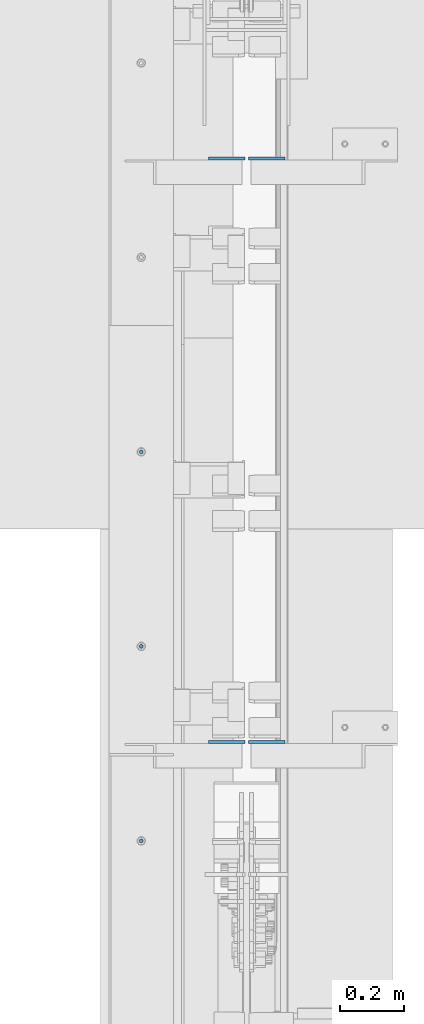
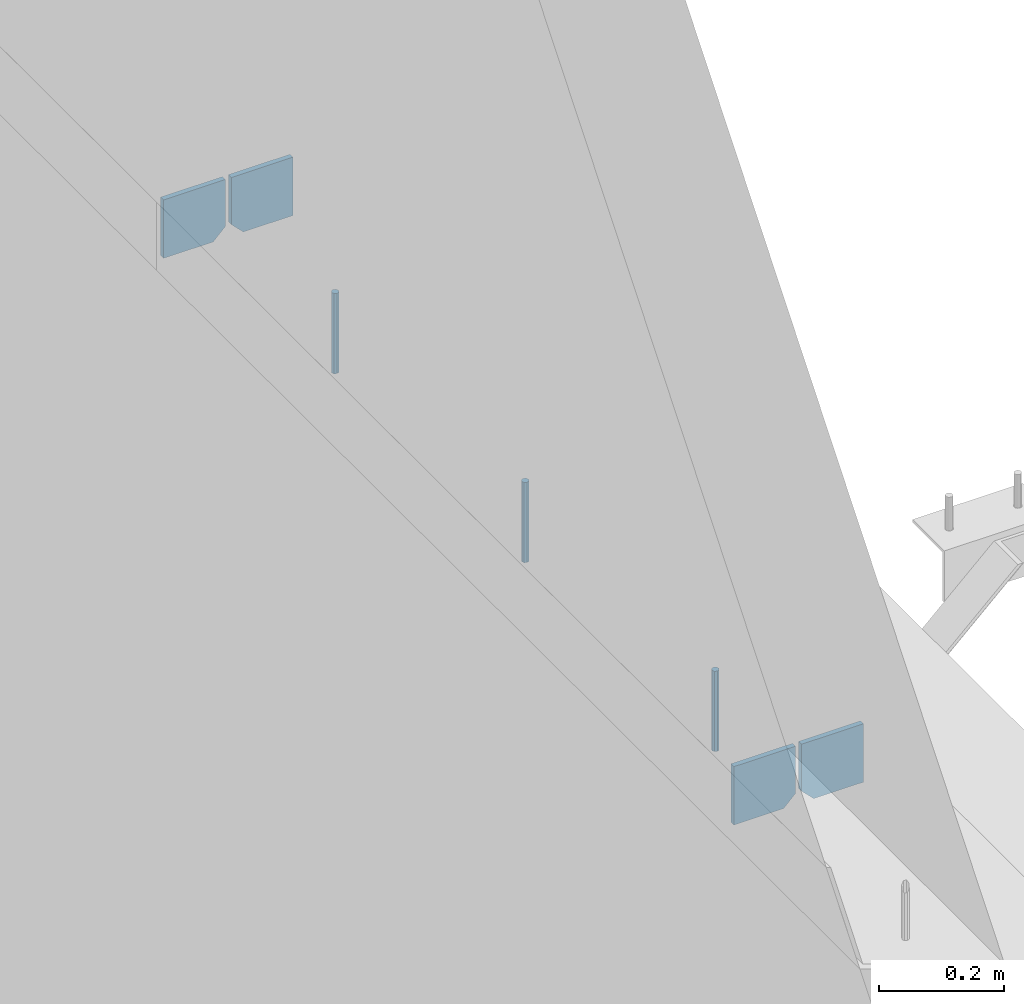
# One storey, part 415 of 1179: 7 columns, 1 element without a shape of its own.
"""IFC2X3 building model written with IfcOpenShell, lengths in millimetres."""

from ifc_helpers import new_model, si_unit, frame, origin_with_axes, place, context, subcontext, project, spatial, faceted_brep, material, type_object, element, aggregate, save


model = new_model("IFC2X3")

# Units and contexts
model_context = context("Model", 3, precision=1e-05, world=origin_with_axes())
body_context = subcontext(model_context, "Body", "Model", "MODEL_VIEW")
ifc_project = project(units=[si_unit("LENGTHUNIT", "METRE", prefix="MILLI"), si_unit("AREAUNIT", "SQUARE_METRE"), si_unit("VOLUMEUNIT", "CUBIC_METRE"), si_unit("MASSUNIT", "GRAM", prefix="KILO"), si_unit("TIMEUNIT", "SECOND"), si_unit("PLANEANGLEUNIT", "RADIAN"), si_unit("SOLIDANGLEUNIT", "STERADIAN"), si_unit("THERMODYNAMICTEMPERATUREUNIT", "DEGREE_CELSIUS"), si_unit("LUMINOUSINTENSITYUNIT", "LUMEN")], contexts=[model_context])

# Site, building, storey
site_placement = place(None, origin_with_axes())
site = spatial("IfcSite", under=ifc_project, at=site_placement, CompositionType="ELEMENT")
building_placement = place(site_placement, origin_with_axes())
building = spatial("IfcBuilding", under=site, at=building_placement, Name="Undefined", CompositionType="ELEMENT")
storey_placement = place(building_placement, origin_with_axes())
storey = spatial("IfcBuildingStorey", under=building, at=storey_placement, Name="Undefined", CompositionType="ELEMENT", Elevation=0.0)

# Assembly, columns
assembly_placement = place(storey_placement, origin_with_axes())
assembly = element("IfcElementAssembly", 1, at=assembly_placement, inside=storey, Name="BEAM", AssemblyPlace="NOTDEFINED", PredefinedType="RIGID_FRAME")
ifc_material_1 = material(Name="STEEL/A36")
column_type_1 = type_object("IfcColumnType", PredefinedType="NOTDEFINED")
column_1_placement = place(assembly_placement, frame((494.506249999998, 18102.2625, 3702.05), z_axis=(-1.0, 0.0, 0.0), x_axis=(0.0, 0.0, 1.0)))
column_1 = element("IfcColumn", 2, at=column_1_placement, type_object=column_type_1, material=ifc_material_1, Name="PLATE", context=body_context, shape_type="Brep", body=[
    faceted_brep([(22.2250000000004, 4.76250000000073, 57.1500000000015), (0.0, 4.76250000000073, 34.9249999999993), (0.0, -4.76250000000073, 34.9249999999993), (22.2250000000004, -4.76250000000073, 57.1500000000015), (114.300000000001, 4.76250000000073, 57.1500000000015), (114.300000000001, 4.76250000000073, -57.1500000000015), (0.0, 4.76250000000073, -57.1500000000015), (114.300000000001, -4.76250000000073, 57.1500000000015), (0.0, -4.76250000000073, -57.1500000000015), (114.300000000001, -4.76250000000073, -57.1500000000015)], [[[0, 1, 2, 3]], [[4, 5, 6, 1, 0]], [[7, 4, 0, 3]], [[8, 9, 7, 3, 2]], [[8, 6, 5, 9]], [[7, 9, 5, 4]], [[6, 8, 2, 1]]]),
])
column_2_placement = place(assembly_placement, frame((369.093750000003, 18102.2625, 3702.05), z_axis=(1.0, 0.0, 0.0), x_axis=(0.0, 0.0, 1.0)))
column_2 = element("IfcColumn", 3, at=column_2_placement, type_object=column_type_1, material=ifc_material_1, Name="PLATE", context=body_context, shape_type="Brep", body=[
    faceted_brep([(22.2250000000004, 4.76250000000073, 57.1500000000015), (0.0, 4.76250000000073, 34.9249999999993), (0.0, -4.76250000000073, 34.9249999999993), (22.2250000000004, -4.76250000000073, 57.1500000000015), (114.300000000001, 4.76250000000073, 57.1500000000015), (114.300000000001, 4.76250000000073, -57.1500000000015), (0.0, 4.76250000000073, -57.1500000000015), (114.300000000001, -4.76250000000073, 57.1500000000015), (0.0, -4.76250000000073, -57.1500000000015), (114.300000000001, -4.76250000000073, -57.1500000000015)], [[[0, 1, 2, 3]], [[4, 5, 6, 1, 0]], [[7, 4, 0, 3]], [[8, 9, 7, 3, 2]], [[8, 6, 5, 9]], [[7, 9, 5, 4]], [[6, 8, 2, 1]]]),
])
column_3_placement = place(assembly_placement, frame((494.506249999998, 16273.4625, 3702.05), z_axis=(-1.0, 0.0, 0.0), x_axis=(0.0, 0.0, 1.0)))
column_3 = element("IfcColumn", 4, at=column_3_placement, type_object=column_type_1, material=ifc_material_1, Name="PLATE", context=body_context, shape_type="Brep", body=[
    faceted_brep([(22.2250000000004, 4.76250000000073, 57.1500000000015), (0.0, 4.76250000000073, 34.9249999999993), (0.0, -4.76250000000073, 34.9249999999993), (22.2250000000004, -4.76250000000073, 57.1500000000015), (114.300000000001, 4.76250000000073, 57.1500000000015), (114.300000000001, 4.76250000000073, -57.1500000000015), (0.0, 4.76250000000073, -57.1500000000015), (114.300000000001, -4.76250000000073, 57.1500000000015), (0.0, -4.76250000000073, -57.1500000000015), (114.300000000001, -4.76250000000073, -57.1500000000015)], [[[0, 1, 2, 3]], [[4, 5, 6, 1, 0]], [[7, 4, 0, 3]], [[8, 9, 7, 3, 2]], [[8, 6, 5, 9]], [[7, 9, 5, 4]], [[6, 8, 2, 1]]]),
])
column_4_placement = place(assembly_placement, frame((369.093750000003, 16273.4625, 3702.05), z_axis=(1.0, 0.0, 0.0), x_axis=(0.0, 0.0, 1.0)))
column_4 = element("IfcColumn", 5, at=column_4_placement, type_object=column_type_1, material=ifc_material_1, Name="PLATE", context=body_context, shape_type="Brep", body=[
    faceted_brep([(22.2250000000004, 4.76250000000073, 57.1500000000015), (0.0, 4.76250000000073, 34.9249999999993), (0.0, -4.76250000000073, 34.9249999999993), (22.2250000000004, -4.76250000000073, 57.1500000000015), (114.300000000001, 4.76250000000073, 57.1500000000015), (114.300000000001, 4.76250000000073, -57.1500000000015), (0.0, 4.76250000000073, -57.1500000000015), (114.300000000001, -4.76250000000073, 57.1500000000015), (0.0, -4.76250000000073, -57.1500000000015), (114.300000000001, -4.76250000000073, -57.1500000000015)], [[[0, 1, 2, 3]], [[4, 5, 6, 1, 0]], [[7, 4, 0, 3]], [[8, 9, 7, 3, 2]], [[8, 6, 5, 9]], [[7, 9, 5, 4]], [[6, 8, 2, 1]]]),
])
ifc_material_2 = material(Name="STEEL/A307")
column_type_2 = type_object("IfcColumnType", PredefinedType="NOTDEFINED")
column_5_placement = place(assembly_placement, frame((101.599999999999, 17183.1, 4108.45), z_axis=(0.0, 1.0, 0.0), x_axis=(0.0, 0.0, 1.0)))
column_5 = element("IfcColumn", 6, at=column_5_placement, type_object=column_type_2, material=ifc_material_2, Name="THREADED ROD", context=body_context, shape_type="Brep", body=[
    faceted_brep([(0.0, -6.34999999999854, 0.0), (0.0, -4.49012806053361, -4.49012806053452), (157.162499999999, -4.49012806053361, -4.49012806053361), (157.162499999999, -6.34999999999854, 0.0), (0.0, 0.0, -6.34999999999991), (157.162499999999, 0.0, -6.34999999999854), (0.0, 4.49012806053361, -4.49012806053452), (157.162499999999, 4.49012806053361, -4.49012806053361), (0.0, 6.34999999999854, 0.0), (157.162499999999, 6.34999999999854, 0.0), (0.0, 4.49012806053361, 4.49012806053452), (157.162499999999, 4.49012806053361, 4.49012806053361), (0.0, 0.0, 6.34999999999991), (157.162499999999, 0.0, 6.34999999999854), (0.0, -4.49012806053361, 4.49012806053452), (157.162499999999, -4.49012806053361, 4.49012806053361)], [[[0, 1, 2, 3]], [[1, 4, 5, 2]], [[4, 6, 7, 5]], [[6, 8, 9, 7]], [[8, 10, 11, 9]], [[10, 12, 13, 11]], [[12, 14, 15, 13]], [[14, 0, 3, 15]], [[5, 7, 9, 11, 13, 15, 3, 2]], [[14, 12, 10, 8, 6, 4, 1, 0]]]),
])
column_6_placement = place(assembly_placement, frame((101.599999999999, 16573.5, 4108.45), z_axis=(0.0, 1.0, 0.0), x_axis=(0.0, 0.0, 1.0)))
column_6 = element("IfcColumn", 7, at=column_6_placement, type_object=column_type_2, material=ifc_material_2, Name="THREADED ROD", context=body_context, shape_type="Brep", body=[
    faceted_brep([(0.0, -6.34999999999854, 0.0), (0.0, -4.49012806053361, -4.49012806053452), (157.162499999999, -4.49012806053361, -4.49012806053361), (157.162499999999, -6.34999999999854, 0.0), (0.0, 0.0, -6.34999999999991), (157.162499999999, 0.0, -6.34999999999854), (0.0, 4.49012806053361, -4.49012806053452), (157.162499999999, 4.49012806053361, -4.49012806053361), (0.0, 6.34999999999854, 0.0), (157.162499999999, 6.34999999999854, 0.0), (0.0, 4.49012806053361, 4.49012806053452), (157.162499999999, 4.49012806053361, 4.49012806053361), (0.0, 0.0, 6.34999999999991), (157.162499999999, 0.0, 6.34999999999854), (0.0, -4.49012806053361, 4.49012806053452), (157.162499999999, -4.49012806053361, 4.49012806053361)], [[[0, 1, 2, 3]], [[1, 4, 5, 2]], [[4, 6, 7, 5]], [[6, 8, 9, 7]], [[8, 10, 11, 9]], [[10, 12, 13, 11]], [[12, 14, 15, 13]], [[14, 0, 3, 15]], [[5, 7, 9, 11, 13, 15, 3, 2]], [[14, 12, 10, 8, 6, 4, 1, 0]]]),
])
column_7_placement = place(assembly_placement, frame((101.599999999999, 15963.9, 4108.45), z_axis=(0.0, 1.0, 0.0), x_axis=(0.0, 0.0, 1.0)))
column_7 = element("IfcColumn", 8, at=column_7_placement, type_object=column_type_2, material=ifc_material_2, Name="THREADED ROD", context=body_context, shape_type="Brep", body=[
    faceted_brep([(0.0, -6.34999999999854, 0.0), (0.0, -4.49012806053361, -4.49012806053452), (157.162499999999, -4.49012806053361, -4.49012806053361), (157.162499999999, -6.34999999999854, 0.0), (0.0, 0.0, -6.34999999999991), (157.162499999999, 0.0, -6.34999999999854), (0.0, 4.49012806053361, -4.49012806053452), (157.162499999999, 4.49012806053361, -4.49012806053361), (0.0, 6.34999999999854, 0.0), (157.162499999999, 6.34999999999854, 0.0), (0.0, 4.49012806053361, 4.49012806053452), (157.162499999999, 4.49012806053361, 4.49012806053361), (0.0, 0.0, 6.34999999999991), (157.162499999999, 0.0, 6.34999999999854), (0.0, -4.49012806053361, 4.49012806053452), (157.162499999999, -4.49012806053361, 4.49012806053361)], [[[0, 1, 2, 3]], [[1, 4, 5, 2]], [[4, 6, 7, 5]], [[6, 8, 9, 7]], [[8, 10, 11, 9]], [[10, 12, 13, 11]], [[12, 14, 15, 13]], [[14, 0, 3, 15]], [[5, 7, 9, 11, 13, 15, 3, 2]], [[14, 12, 10, 8, 6, 4, 1, 0]]]),
])
aggregate(assembly, [column_1, column_2, column_5, column_6, column_7, column_3, column_4])

save(model, "model.ifc")
